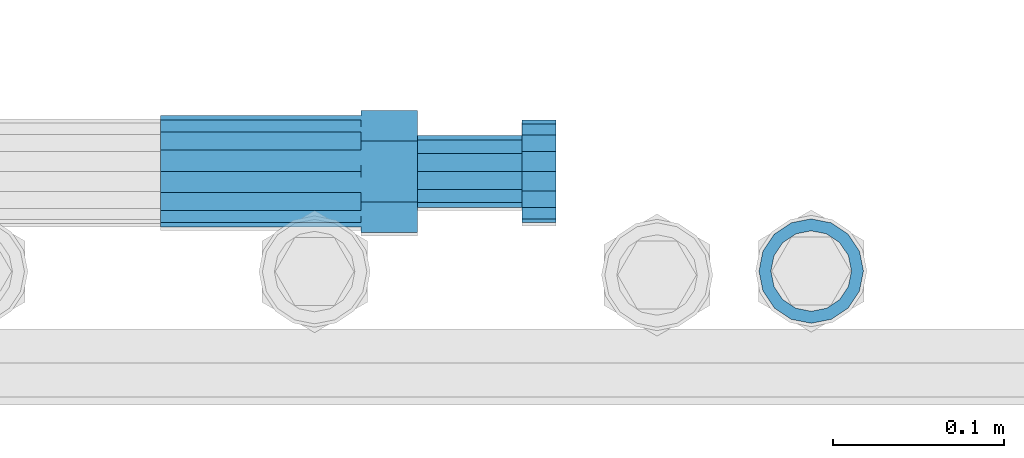
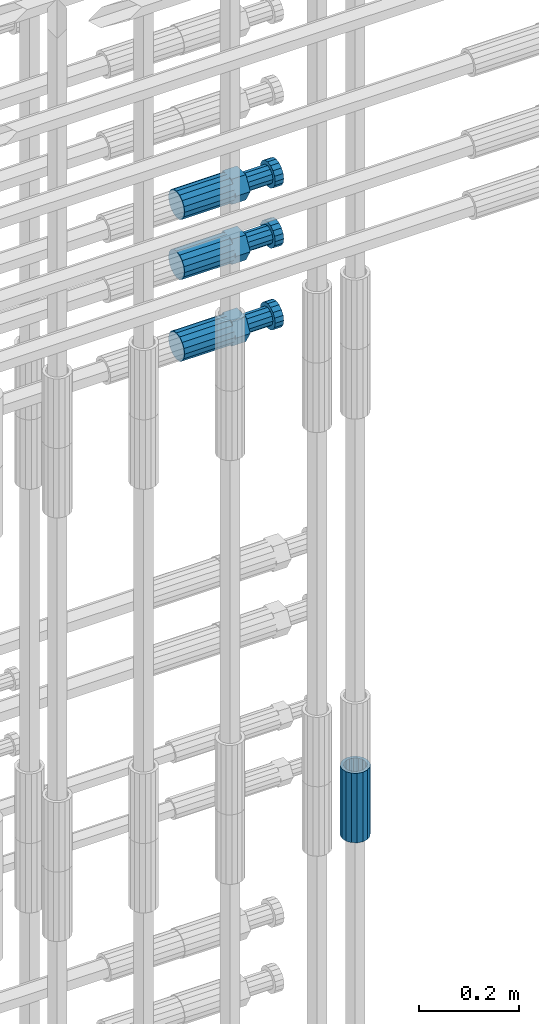
# One storey, part 101 of 119: 4 beams.
"""IFC2X3 building model written with IfcOpenShell, lengths in millimetres."""

from ifc_helpers import new_model, si_unit, frame, origin_with_axes, place, context, subcontext, project, spatial, faceted_brep, material, type_object, element, save


model = new_model("IFC2X3")

# Units and contexts
model_context = context("Model", 3, precision=1e-05, world=origin_with_axes())
body_context = subcontext(model_context, "Body", "Model", "MODEL_VIEW")
ifc_project = project(units=[si_unit("LENGTHUNIT", "METRE", prefix="MILLI"), si_unit("AREAUNIT", "SQUARE_METRE"), si_unit("VOLUMEUNIT", "CUBIC_METRE"), si_unit("MASSUNIT", "GRAM", prefix="KILO"), si_unit("TIMEUNIT", "SECOND"), si_unit("PLANEANGLEUNIT", "RADIAN"), si_unit("SOLIDANGLEUNIT", "STERADIAN"), si_unit("THERMODYNAMICTEMPERATUREUNIT", "DEGREE_CELSIUS"), si_unit("LUMINOUSINTENSITYUNIT", "LUMEN")], contexts=[model_context])

# Site, building, storey
site_placement = place(None, origin_with_axes())
site = spatial("IfcSite", under=ifc_project, at=site_placement, CompositionType="ELEMENT")
building_placement = place(site_placement, origin_with_axes())
building = spatial("IfcBuilding", under=site, at=building_placement, Name="Undefined", CompositionType="ELEMENT")
storey_placement = place(building_placement, origin_with_axes())
storey = spatial("IfcBuildingStorey", under=building, at=storey_placement, Name="Undefined", CompositionType="ELEMENT", Elevation=0.0)

# Beams
ifc_material = material(Name="STEEL/S275")
beam_type_1 = type_object("IfcBeamType", PredefinedType="NOTDEFINED")
beam_1_placement = place(storey_placement, frame((2039119.0136987, 6205156.73095221, 19667.715729163), z_axis=(1.0, 0.0, 0.0), x_axis=(0.0, 0.0, 1.0)))
element("IfcBeam", 1, at=beam_1_placement, inside=storey, type_object=beam_type_1, material=ifc_material, Name="AG40N", context=body_context, shape_type="Brep", body=[
    faceted_brep([(1.62981450557709e-09, -23.4999999990687, 0.0), (7.45058059692383e-09, -21.7111690142192, 8.99306066057534), (170.000002125278, -21.711168999318, 8.99306066022245), (170.000002127141, -23.4999999844003, -3.66071617463604e-10), (4.65661287307739e-09, -16.6170093587134, 16.6170093578889), (170.000002122484, -16.6170093440451, 16.6170093575288), (1.86264514923096e-09, -8.99306066217832, 21.7111690140277), (170.000002118759, -8.99306064750999, 21.7111690136603), (2.3283064365387e-10, 9.31322574615479e-10, 23.5), (170.000002114102, 1.28056854009628e-08, 23.4999999996485), (-6.51925802230835e-09, 8.99306065868586, 21.7111690140241), (170.00000211224, 8.99306067335419, 21.7111690136639), (-7.45058059692383e-09, 16.6170093561523, 16.6170093578853), (170.000002109446, 16.6170093708206, 16.6170093575324), (-9.31322574615479e-09, 21.711169013055, 8.99306066057534), (170.000002108514, 21.7111690277234, 8.99306066022245), (-1.16415321826935e-09, 23.5000000009313, 0.0), (170.000002108514, 23.5000000144355, -3.66071617463604e-10), (-8.38190317153931e-09, 21.7111690151505, -8.99306066059444), (170.000002110377, 21.7111690300517, -8.9930606609546), (-5.58793544769287e-09, 16.6170093598776, -16.6170093579008), (170.000002113171, 16.6170093745459, -16.6170093582609), (-9.31322574615479e-10, 8.99306066334248, -21.7111690140396), (170.000002115965, 8.99306067801081, -21.7111690143961), (2.3283064365387e-10, 9.31322574615479e-10, -23.5), (170.00000211969, 1.7927959561348e-08, -23.5000000003843), (5.58793544769287e-09, -8.99306065752171, -21.7111690140396), (170.000002123415, -8.99306064285338, -21.7111690143961), (8.38190317153931e-09, -16.6170093549881, -16.6170093579008), (170.000002125278, -16.6170093403198, -16.6170093582646), (9.31322574615479e-09, -21.7111690121237, -8.99306066059444), (170.000002127141, -21.7111689972226, -8.9930606609546), (1.11758708953857e-08, -30.4999999990687, -9.54969436861575e-12), (1.30385160446167e-08, -28.1783257392235, -11.6718446871514), (170.000002129003, -28.1783257243223, -11.6718446875116), (170.000002129935, -30.4999999841675, -3.66071617463604e-10), (1.02445483207703e-08, -21.5667568228673, -21.5667568262129), (170.000002128072, -21.566756808199, -21.5667568265694), (7.45058059692383e-09, -11.6718446831219, -28.1783257416196), (170.000002125278, -11.6718446684536, -28.1783257419834), (3.72529029846191e-09, 3.95812094211578e-09, -30.5000000000277), (170.00000211969, 1.83936208486557e-08, -30.5000000003879), (-9.31322574615479e-10, 11.6718446905725, -28.1783257416232), (170.000002115965, 11.6718447052408, -28.1783257419797), (-6.51925802230835e-09, 21.5667568286881, -21.5667568262093), (170.000002110377, 21.5667568433564, -21.5667568265694), (-9.31322574615479e-09, 28.178325742716, -11.6718446871478), (170.000002108514, 28.1783257573843, -11.6718446875079), (-1.21071934700012e-08, 30.5, -5.91171556152403e-12), (170.000002106652, 30.5000000144355, -3.62433638656512e-10), (-1.21071934700012e-08, 28.1783257401548, 11.6718446871359), (170.00000210572, 28.1783257548232, 11.6718446867794), (-1.02445483207703e-08, 21.5667568240315, 21.5667568261974), (170.000002107583, 21.566756838467, 21.5667568258409), (-7.45058059692383e-09, 11.671844684286, 28.1783257416041), (170.000002110377, 11.6718446989544, 28.178325741244), (-2.79396772384644e-09, -2.56113708019257e-09, 30.5000000000159), (170.000002114102, 1.18743628263474e-08, 30.4999999996558), (1.86264514923096e-09, -11.6718446896411, 28.1783257416114), (170.000002118759, -11.67184467474, 28.178325741244), (7.45058059692383e-09, -21.5667568275239, 21.5667568261974), (170.000002123415, -21.5667568126228, 21.5667568258373), (1.02445483207703e-08, -28.1783257415518, 11.6718446871359), (170.000002127141, -28.1783257271163, 11.6718446867794)], [[[0, 1, 2, 3]], [[1, 4, 5, 2]], [[4, 6, 7, 5]], [[6, 8, 9, 7]], [[8, 10, 11, 9]], [[10, 12, 13, 11]], [[12, 14, 15, 13]], [[14, 16, 17, 15]], [[16, 18, 19, 17]], [[18, 20, 21, 19]], [[20, 22, 23, 21]], [[22, 24, 25, 23]], [[24, 26, 27, 25]], [[26, 28, 29, 27]], [[28, 30, 31, 29]], [[30, 0, 3, 31]], [[32, 33, 34, 35]], [[33, 36, 37, 34]], [[36, 38, 39, 37]], [[38, 40, 41, 39]], [[40, 42, 43, 41]], [[42, 44, 45, 43]], [[44, 46, 47, 45]], [[46, 48, 49, 47]], [[48, 50, 51, 49]], [[50, 52, 53, 51]], [[52, 54, 55, 53]], [[54, 56, 57, 55]], [[56, 58, 59, 57]], [[58, 60, 61, 59]], [[60, 62, 63, 61]], [[62, 32, 35, 63]], [[37, 39, 41, 43, 45, 47, 49, 51, 53, 55, 57, 59, 61, 63, 35, 34], [5, 7, 9, 11, 13, 15, 17, 19, 21, 23, 25, 27, 29, 31, 3, 2]], [[62, 60, 58, 56, 54, 52, 50, 48, 46, 44, 42, 40, 38, 36, 33, 32], [30, 28, 26, 24, 22, 20, 18, 16, 14, 12, 10, 8, 6, 4, 1, 0]]]),
])
beam_type_2 = type_object("IfcBeamType", Name="ROD65", PredefinedType="NOTDEFINED")
beam_2_placement = place(storey_placement, frame((2038739.00023304, 6205214.98994599, 21306.9894219673), z_axis=(0.0, 0.0, 1.0), x_axis=(1.0, 0.0, 0.0)))
element("IfcBeam", 2, at=beam_2_placement, inside=storey, type_object=beam_type_2, material=ifc_material, Name="AGB40", ObjectType="ROD65", context=body_context, shape_type="Brep", body=[
    faceted_brep([(116.999999999069, 17.8249999252148, 30.8738056446964), (116.999999998137, 22.0056957420893, 23.632628078838), (116.999999999069, 12.4372115600854, 30.0260848066173), (116.999999999069, 8.17543111252598, 30.8738056446964), (117.000000000931, -17.8250000746921, 30.8738056446964), (150.200000001118, -17.8250000723638, 30.8738056446964), (150.199999999255, 17.8249999275431, 30.8738056446964), (117.000000000931, -8.17543109622784, 30.8738056446964), (117.000000001863, -22.0056959956419, 23.6326278985034), (117.000000000931, -12.4372115437873, 30.0260848066173), (117.000000001863, -35.6500000746455, -2.18278728425503e-10), (150.200000002049, -35.6500000723172, -2.18278728425503e-10), (117.000000001863, -30.8443149488885, 8.32369080289209), (117.000000001863, -30.8443149488885, -8.32369080355784), (117.000000002794, -32.4999999918509, 0.0), (117.000000000931, -17.8250000746921, -30.873805645133), (150.200000001118, -17.8250000723638, -30.873805645133), (117.000000001863, -22.0056959961075, -23.6326278982269), (117.000000000931, -8.17543109389953, -30.873805645133), (117.000000000931, -12.4372115437873, -30.0260848066173), (116.999999999069, 17.8249999252148, -30.873805645133), (150.199999999255, 17.8249999275431, -30.873805645133), (116.999999999069, 8.17543111019768, -30.873805645133), (116.999999999069, 12.4372115600854, -30.0260848066173), (116.999999998137, 22.005695742555, -23.6326280785652), (116.999999998137, 35.6499999251682, -2.18278728425503e-10), (150.199999998324, 35.6499999277294, -2.18278728425503e-10), (116.999999998137, 30.8443150522653, -8.32369036550881), (116.999999997206, 32.5000000081491, 0.0), (116.999999998137, 30.8443150522653, 8.32369036483942), (1.86264514923096e-09, -22.9809703885112, 22.9809703885621), (1.86264514923096e-09, -30.0260848065373, 12.4372115518672), (117.000000001863, -30.0260847983882, 12.4372115518672), (117.000000001863, -22.9809703803621, 22.9809703885621), (-1.86264514923096e-09, 22.9809703885112, -22.9809703885621), (-1.86264514923096e-09, 30.0260848065373, -12.4372115518672), (116.999999998137, 30.0260848146863, -12.4372115518672), (116.999999998137, 22.9809703966603, -22.9809703885621), (1.86264514923096e-09, -30.0260848065373, -12.4372115518672), (1.86264514923096e-09, -22.9809703885112, -22.9809703885621), (117.000000001863, -22.9809703803621, -22.9809703885621), (117.000000001863, -30.0260847983882, -12.4372115518672), (9.31322574615479e-10, -12.4372115519363, 30.0260848066173), (0.0, 0.0, 32.5), (-9.31322574615479e-10, 12.4372115519363, 30.0260848066173), (-1.86264514923096e-09, 22.9809703885112, 22.9809703885621), (-1.86264514923096e-09, 30.0260848065373, 12.4372115518672), (-2.79396772384644e-09, 32.5, 0.0), (-9.31322574615479e-10, 12.4372115519363, -30.0260848066173), (0.0, 0.0, -32.5), (9.31322574615479e-10, -12.4372115519363, -30.0260848066173), (2.79396772384644e-09, -32.5, 0.0), (116.999999998137, 22.9809703966603, 22.9809703885621), (116.999999998137, 30.0260848146863, 12.4372115518672), (117.0, 8.14907252788544e-09, -32.5), (117.0, 8.14907252788544e-09, 32.5), (150.200000000186, -10.5000000959262, 18.1865334791873), (150.199999999255, -9.59262251853943e-08, 20.9999999997126), (150.199999998324, 10.4999999040738, 18.1865334791873), (150.199999997392, 18.1865333835594, 10.4999999997126), (150.199999997392, 20.9999999040738, -2.87400325760245e-10), (150.199999997392, 18.1865333835594, -10.5000000002874), (150.199999998324, 10.4999999040738, -18.1865334797621), (150.199999999255, -9.59262251853943e-08, -21.0000000002874), (150.200000000186, -10.5000000959262, -18.1865334797621), (150.200000000186, -18.1865335754119, -10.5000000002874), (150.200000001118, -21.0000000959262, -2.87400325760245e-10), (150.200000000186, -18.1865335754119, 10.4999999997126), (210.979999999516, 10.4999999082647, 18.1865334791873), (210.979999999516, -9.17352735996246e-08, 20.9999999997126), (210.979999997653, 18.1865333877504, 10.4999999997126), (210.979999997653, 20.9999999082647, -2.87400325760245e-10), (210.979999997653, 18.1865333877504, -10.5000000002874), (210.979999999516, 10.4999999082647, -18.1865334797621), (210.979999999516, -9.17352735996246e-08, -21.0000000002874), (210.979999999516, -10.5000000917353, -18.1865334797621), (210.980000000447, -18.1865335712209, -10.5000000002874), (210.980000001378, -21.0000000917353, -2.87400325760245e-10), (210.980000000447, -18.1865335712209, 10.4999999997126), (210.979999999516, -10.5000000917353, 18.1865334791873), (211.001368402503, -27.7269939335529, -11.4911163272045), (211.003082515672, -21.2238095656503, -21.2238154190527), (231.002518340945, -21.2131946226582, -21.2132004554769), (231.000804228708, -27.7163789905608, -11.4805013636287), (211.001368415542, -11.4911086384673, -27.7269970399575), (231.000804241747, -11.4804936954752, -27.7163820763781), (210.996487061493, -0.0106066407170147, -30.0106107396168), (230.995922887698, 8.30227509140968e-06, -29.999995776041), (210.98918159306, 11.4698940692469, -27.7269970332745), (230.988617419265, 11.4805090120062, -27.7163820696951), (210.980564201251, 21.2025913291145, -21.2238154067054), (230.980000027455, 21.2132062721066, -21.2132004431296), (210.971946807578, 27.7057702087332, -11.4911163110701), (230.971382633783, 27.7163851517253, -11.4805013474943), (210.964641331695, 29.9893806746695, -0.0106149565435771), (230.9640771579, 29.9999956176616, 7.03221303410828e-09), (210.959759964608, 27.7057637346443, 11.4698863966551), (230.959195790812, 27.7163786776364, 11.4805013602345), (210.958045851439, 21.2025793667417, 21.2025854885032), (230.957481677644, 21.2131943097338, 21.2132004520827), (210.959759951569, 11.4698784395587, 27.705767109408), (230.959195776843, 11.4804933823179, 27.7163820729838), (210.964641305618, -0.0106235581915826, 29.9893808090674), (230.964077131823, -8.61519947648048e-06, 29.9999957726432), (210.971946774051, -11.4911242681555, 27.7057671027251), (230.971382599324, -11.4805093251634, 27.7163820663009), (210.98056416586, -21.2238215280231, 21.2025854761559), (230.979999991134, -21.2132065852638, 21.2132004397354), (210.989181559533, -27.7270004076418, 11.4698863805206), (230.988617384806, -27.7163854646496, 11.4805013441), (210.996487035416, -30.0106108735781, -0.0106149740058754), (230.995922861621, -29.999995930586, -1.04300852399319e-08)], [[[0, 1, 2, 3]], [[4, 5, 6, 0, 3, 7]], [[8, 4, 7, 9]], [[10, 11, 5, 4, 8, 12]], [[13, 10, 12, 14]], [[15, 16, 11, 10, 13, 17]], [[18, 15, 17, 19]], [[20, 21, 16, 15, 18, 22]], [[20, 22, 23, 24]], [[25, 26, 21, 20, 24, 27]], [[25, 27, 28, 29]], [[30, 31, 32, 33]], [[34, 35, 36, 37]], [[38, 39, 40, 41]], [[31, 30, 42, 43, 44, 45, 46, 47, 35, 34, 48, 49, 50, 39, 38, 51]], [[46, 45, 52, 53]], [[28, 47, 46, 53, 29]], [[27, 36, 35, 47, 28]], [[24, 37, 36, 27]], [[23, 48, 34, 37, 24]], [[22, 54, 49, 48, 23]], [[18, 54, 22]], [[19, 50, 49, 54, 18]], [[17, 40, 39, 50, 19]], [[13, 41, 40, 17]], [[14, 51, 38, 41, 13]], [[12, 32, 31, 51, 14]], [[8, 33, 32, 12]], [[9, 42, 30, 33, 8]], [[7, 55, 43, 42, 9]], [[3, 55, 7]], [[2, 44, 43, 55, 3]], [[1, 52, 45, 44, 2]], [[29, 53, 52, 1]], [[0, 6, 26, 25, 29, 1]], [[5, 11, 16, 21, 26, 6], [56, 57, 58, 59, 60, 61, 62, 63, 64, 65, 66, 67]], [[68, 58, 57, 69]], [[70, 59, 58, 68]], [[71, 60, 59, 70]], [[72, 61, 60, 71]], [[73, 62, 61, 72]], [[74, 63, 62, 73]], [[75, 64, 63, 74]], [[76, 65, 64, 75]], [[77, 66, 65, 76]], [[78, 67, 66, 77]], [[79, 56, 67, 78]], [[69, 57, 56, 79]], [[80, 81, 82, 83]], [[81, 84, 85, 82]], [[84, 86, 87, 85]], [[86, 88, 89, 87]], [[88, 90, 91, 89]], [[90, 92, 93, 91]], [[92, 94, 95, 93]], [[94, 96, 97, 95]], [[96, 98, 99, 97]], [[98, 100, 101, 99]], [[100, 102, 103, 101]], [[102, 104, 105, 103]], [[104, 106, 107, 105]], [[106, 108, 109, 107]], [[108, 110, 111, 109]], [[82, 85, 87, 89, 91, 93, 95, 97, 99, 101, 103, 105, 107, 109, 111, 83]], [[110, 80, 83, 111]], [[108, 106, 104, 102, 100, 98, 96, 94, 92, 90, 88, 86, 84, 81, 80, 110], [78, 77, 76, 75, 74, 73, 72, 71, 70, 68, 69, 79]]]),
])
beam_3_placement = place(storey_placement, frame((2038739.00023304, 6205214.98994599, 21159.9894219673), z_axis=(0.0, 0.0, 1.0), x_axis=(1.0, 0.0, 0.0)))
element("IfcBeam", 3, at=beam_3_placement, inside=storey, type_object=beam_type_2, material=ifc_material, Name="AGB40", ObjectType="ROD65", context=body_context, shape_type="Brep", body=[
    faceted_brep([(116.999999999069, 17.8249999252148, 30.8738056446964), (116.999999998137, 22.0056957420893, 23.632628078838), (116.999999999069, 12.4372115600854, 30.0260848066173), (116.999999999069, 8.17543111252598, 30.8738056446964), (117.000000000931, -17.8250000746921, 30.8738056446964), (150.200000001118, -17.8250000723638, 30.8738056446964), (150.199999999255, 17.8249999275431, 30.8738056446964), (117.000000000931, -8.17543109622784, 30.8738056446964), (117.000000001863, -22.0056959956419, 23.6326278985034), (117.000000000931, -12.4372115437873, 30.0260848066173), (117.000000001863, -35.6500000746455, -2.18278728425503e-10), (150.200000002049, -35.6500000723172, -2.18278728425503e-10), (117.000000001863, -30.8443149488885, 8.32369080289209), (117.000000001863, -30.8443149488885, -8.32369080355784), (117.000000002794, -32.4999999918509, 0.0), (117.000000000931, -17.8250000746921, -30.873805645133), (150.200000001118, -17.8250000723638, -30.873805645133), (117.000000001863, -22.0056959961075, -23.6326278982269), (117.000000000931, -8.17543109389953, -30.873805645133), (117.000000000931, -12.4372115437873, -30.0260848066173), (116.999999999069, 17.8249999252148, -30.873805645133), (150.199999999255, 17.8249999275431, -30.873805645133), (116.999999999069, 8.17543111019768, -30.873805645133), (116.999999999069, 12.4372115600854, -30.0260848066173), (116.999999998137, 22.005695742555, -23.6326280785652), (116.999999998137, 35.6499999251682, -2.18278728425503e-10), (150.199999998324, 35.6499999277294, -2.18278728425503e-10), (116.999999998137, 30.8443150522653, -8.32369036550881), (116.999999997206, 32.5000000081491, 0.0), (116.999999998137, 30.8443150522653, 8.32369036483942), (1.86264514923096e-09, -22.9809703885112, 22.9809703885621), (1.86264514923096e-09, -30.0260848065373, 12.4372115518672), (117.000000001863, -30.0260847983882, 12.4372115518672), (117.000000001863, -22.9809703803621, 22.9809703885621), (-1.86264514923096e-09, 22.9809703885112, -22.9809703885621), (-1.86264514923096e-09, 30.0260848065373, -12.4372115518672), (116.999999998137, 30.0260848146863, -12.4372115518672), (116.999999998137, 22.9809703966603, -22.9809703885621), (1.86264514923096e-09, -30.0260848065373, -12.4372115518672), (1.86264514923096e-09, -22.9809703885112, -22.9809703885621), (117.000000001863, -22.9809703803621, -22.9809703885621), (117.000000001863, -30.0260847983882, -12.4372115518672), (9.31322574615479e-10, -12.4372115519363, 30.0260848066173), (0.0, 0.0, 32.5), (-9.31322574615479e-10, 12.4372115519363, 30.0260848066173), (-1.86264514923096e-09, 22.9809703885112, 22.9809703885621), (-1.86264514923096e-09, 30.0260848065373, 12.4372115518672), (-2.79396772384644e-09, 32.5, 0.0), (-9.31322574615479e-10, 12.4372115519363, -30.0260848066173), (0.0, 0.0, -32.5), (9.31322574615479e-10, -12.4372115519363, -30.0260848066173), (2.79396772384644e-09, -32.5, 0.0), (116.999999998137, 22.9809703966603, 22.9809703885621), (116.999999998137, 30.0260848146863, 12.4372115518672), (117.0, 8.14907252788544e-09, -32.5), (117.0, 8.14907252788544e-09, 32.5), (150.200000000186, -10.5000000959262, 18.1865334791873), (150.199999999255, -9.59262251853943e-08, 20.9999999997126), (150.199999998324, 10.4999999040738, 18.1865334791873), (150.199999997392, 18.1865333835594, 10.4999999997126), (150.199999997392, 20.9999999040738, -2.87400325760245e-10), (150.199999997392, 18.1865333835594, -10.5000000002874), (150.199999998324, 10.4999999040738, -18.1865334797621), (150.199999999255, -9.59262251853943e-08, -21.0000000002874), (150.200000000186, -10.5000000959262, -18.1865334797621), (150.200000000186, -18.1865335754119, -10.5000000002874), (150.200000001118, -21.0000000959262, -2.87400325760245e-10), (150.200000000186, -18.1865335754119, 10.4999999997126), (210.979999999516, 10.4999999082647, 18.1865334791873), (210.979999999516, -9.17352735996246e-08, 20.9999999997126), (210.979999997653, 18.1865333877504, 10.4999999997126), (210.979999997653, 20.9999999082647, -2.87400325760245e-10), (210.979999997653, 18.1865333877504, -10.5000000002874), (210.979999999516, 10.4999999082647, -18.1865334797621), (210.979999999516, -9.17352735996246e-08, -21.0000000002874), (210.979999999516, -10.5000000917353, -18.1865334797621), (210.980000000447, -18.1865335712209, -10.5000000002874), (210.980000001378, -21.0000000917353, -2.87400325760245e-10), (210.980000000447, -18.1865335712209, 10.4999999997126), (210.979999999516, -10.5000000917353, 18.1865334791873), (211.001368402503, -27.7269939335529, -11.4911163272045), (211.003082515672, -21.2238095656503, -21.2238154190527), (231.002518340945, -21.2131946226582, -21.2132004554769), (231.000804228708, -27.7163789905608, -11.4805013636287), (211.001368415542, -11.4911086384673, -27.7269970399575), (231.000804241747, -11.4804936954752, -27.7163820763781), (210.996487061493, -0.0106066407170147, -30.0106107396168), (230.995922887698, 8.30227509140968e-06, -29.999995776041), (210.98918159306, 11.4698940692469, -27.7269970332745), (230.988617419265, 11.4805090120062, -27.7163820696951), (210.980564201251, 21.2025913291145, -21.2238154067054), (230.980000027455, 21.2132062721066, -21.2132004431296), (210.971946807578, 27.7057702087332, -11.4911163110701), (230.971382633783, 27.7163851517253, -11.4805013474943), (210.964641331695, 29.9893806746695, -0.0106149565435771), (230.9640771579, 29.9999956176616, 7.03221303410828e-09), (210.959759964608, 27.7057637346443, 11.4698863966551), (230.959195790812, 27.7163786776364, 11.4805013602345), (210.958045851439, 21.2025793667417, 21.2025854885032), (230.957481677644, 21.2131943097338, 21.2132004520827), (210.959759951569, 11.4698784395587, 27.705767109408), (230.959195776843, 11.4804933823179, 27.7163820729838), (210.964641305618, -0.0106235581915826, 29.9893808090674), (230.964077131823, -8.61519947648048e-06, 29.9999957726432), (210.971946774051, -11.4911242681555, 27.7057671027251), (230.971382599324, -11.4805093251634, 27.7163820663009), (210.98056416586, -21.2238215280231, 21.2025854761559), (230.979999991134, -21.2132065852638, 21.2132004397354), (210.989181559533, -27.7270004076418, 11.4698863805206), (230.988617384806, -27.7163854646496, 11.4805013441), (210.996487035416, -30.0106108735781, -0.0106149740058754), (230.995922861621, -29.999995930586, -1.04300852399319e-08)], [[[0, 1, 2, 3]], [[4, 5, 6, 0, 3, 7]], [[8, 4, 7, 9]], [[10, 11, 5, 4, 8, 12]], [[13, 10, 12, 14]], [[15, 16, 11, 10, 13, 17]], [[18, 15, 17, 19]], [[20, 21, 16, 15, 18, 22]], [[20, 22, 23, 24]], [[25, 26, 21, 20, 24, 27]], [[25, 27, 28, 29]], [[30, 31, 32, 33]], [[34, 35, 36, 37]], [[38, 39, 40, 41]], [[31, 30, 42, 43, 44, 45, 46, 47, 35, 34, 48, 49, 50, 39, 38, 51]], [[46, 45, 52, 53]], [[28, 47, 46, 53, 29]], [[27, 36, 35, 47, 28]], [[24, 37, 36, 27]], [[23, 48, 34, 37, 24]], [[22, 54, 49, 48, 23]], [[18, 54, 22]], [[19, 50, 49, 54, 18]], [[17, 40, 39, 50, 19]], [[13, 41, 40, 17]], [[14, 51, 38, 41, 13]], [[12, 32, 31, 51, 14]], [[8, 33, 32, 12]], [[9, 42, 30, 33, 8]], [[7, 55, 43, 42, 9]], [[3, 55, 7]], [[2, 44, 43, 55, 3]], [[1, 52, 45, 44, 2]], [[29, 53, 52, 1]], [[0, 6, 26, 25, 29, 1]], [[5, 11, 16, 21, 26, 6], [56, 57, 58, 59, 60, 61, 62, 63, 64, 65, 66, 67]], [[68, 58, 57, 69]], [[70, 59, 58, 68]], [[71, 60, 59, 70]], [[72, 61, 60, 71]], [[73, 62, 61, 72]], [[74, 63, 62, 73]], [[75, 64, 63, 74]], [[76, 65, 64, 75]], [[77, 66, 65, 76]], [[78, 67, 66, 77]], [[79, 56, 67, 78]], [[69, 57, 56, 79]], [[80, 81, 82, 83]], [[81, 84, 85, 82]], [[84, 86, 87, 85]], [[86, 88, 89, 87]], [[88, 90, 91, 89]], [[90, 92, 93, 91]], [[92, 94, 95, 93]], [[94, 96, 97, 95]], [[96, 98, 99, 97]], [[98, 100, 101, 99]], [[100, 102, 103, 101]], [[102, 104, 105, 103]], [[104, 106, 107, 105]], [[106, 108, 109, 107]], [[108, 110, 111, 109]], [[82, 85, 87, 89, 91, 93, 95, 97, 99, 101, 103, 105, 107, 109, 111, 83]], [[110, 80, 83, 111]], [[108, 106, 104, 102, 100, 98, 96, 94, 92, 90, 88, 86, 84, 81, 80, 110], [78, 77, 76, 75, 74, 73, 72, 71, 70, 68, 69, 79]]]),
])
beam_4_placement = place(storey_placement, frame((2038739.00023304, 6205214.98994599, 20959.9894220935), z_axis=(0.0, 0.0, 1.0), x_axis=(1.0, 0.0, 0.0)))
element("IfcBeam", 4, at=beam_4_placement, inside=storey, type_object=beam_type_2, material=ifc_material, Name="AGB40", ObjectType="ROD65", context=body_context, shape_type="Brep", body=[
    faceted_brep([(116.999999999069, 17.8249999252148, 30.8738056446964), (116.999999998137, 22.0056957420893, 23.632628078838), (116.999999999069, 12.4372115600854, 30.0260848066173), (116.999999999069, 8.17543111252598, 30.8738056446964), (117.000000000931, -17.8250000746921, 30.8738056446964), (150.200000001118, -17.8250000723638, 30.8738056446964), (150.199999999255, 17.8249999275431, 30.8738056446964), (117.000000000931, -8.17543109622784, 30.8738056446964), (117.000000001863, -22.0056959956419, 23.6326278985034), (117.000000000931, -12.4372115437873, 30.0260848066173), (117.000000001863, -35.6500000746455, -2.18278728425503e-10), (150.200000002049, -35.6500000723172, -2.18278728425503e-10), (117.000000001863, -30.8443149488885, 8.32369080289209), (117.000000001863, -30.8443149488885, -8.32369080355784), (117.000000002794, -32.4999999918509, 0.0), (117.000000000931, -17.8250000746921, -30.873805645133), (150.200000001118, -17.8250000723638, -30.873805645133), (117.000000001863, -22.0056959961075, -23.6326278982269), (117.000000000931, -8.17543109389953, -30.873805645133), (117.000000000931, -12.4372115437873, -30.0260848066173), (116.999999999069, 17.8249999252148, -30.873805645133), (150.199999999255, 17.8249999275431, -30.873805645133), (116.999999999069, 8.17543111019768, -30.873805645133), (116.999999999069, 12.4372115600854, -30.0260848066173), (116.999999998137, 22.005695742555, -23.6326280785652), (116.999999998137, 35.6499999251682, -2.18278728425503e-10), (150.199999998324, 35.6499999277294, -2.18278728425503e-10), (116.999999998137, 30.8443150522653, -8.32369036550881), (116.999999997206, 32.5000000081491, 0.0), (116.999999998137, 30.8443150522653, 8.32369036483942), (1.86264514923096e-09, -22.9809703885112, 22.9809703885621), (1.86264514923096e-09, -30.0260848065373, 12.4372115518672), (117.000000001863, -30.0260847983882, 12.4372115518672), (117.000000001863, -22.9809703803621, 22.9809703885621), (-1.86264514923096e-09, 22.9809703885112, -22.9809703885621), (-1.86264514923096e-09, 30.0260848065373, -12.4372115518672), (116.999999998137, 30.0260848146863, -12.4372115518672), (116.999999998137, 22.9809703966603, -22.9809703885621), (1.86264514923096e-09, -30.0260848065373, -12.4372115518672), (1.86264514923096e-09, -22.9809703885112, -22.9809703885621), (117.000000001863, -22.9809703803621, -22.9809703885621), (117.000000001863, -30.0260847983882, -12.4372115518672), (9.31322574615479e-10, -12.4372115519363, 30.0260848066173), (0.0, 0.0, 32.5), (-9.31322574615479e-10, 12.4372115519363, 30.0260848066173), (-1.86264514923096e-09, 22.9809703885112, 22.9809703885621), (-1.86264514923096e-09, 30.0260848065373, 12.4372115518672), (-2.79396772384644e-09, 32.5, 0.0), (-9.31322574615479e-10, 12.4372115519363, -30.0260848066173), (0.0, 0.0, -32.5), (9.31322574615479e-10, -12.4372115519363, -30.0260848066173), (2.79396772384644e-09, -32.5, 0.0), (116.999999998137, 22.9809703966603, 22.9809703885621), (116.999999998137, 30.0260848146863, 12.4372115518672), (117.0, 8.14907252788544e-09, -32.5), (117.0, 8.14907252788544e-09, 32.5), (150.200000000186, -10.5000000959262, 18.1865334791873), (150.199999999255, -9.59262251853943e-08, 20.9999999997126), (150.199999998324, 10.4999999040738, 18.1865334791873), (150.199999997392, 18.1865333835594, 10.4999999997126), (150.199999997392, 20.9999999040738, -2.87400325760245e-10), (150.199999997392, 18.1865333835594, -10.5000000002874), (150.199999998324, 10.4999999040738, -18.1865334797621), (150.199999999255, -9.59262251853943e-08, -21.0000000002874), (150.200000000186, -10.5000000959262, -18.1865334797621), (150.200000000186, -18.1865335754119, -10.5000000002874), (150.200000001118, -21.0000000959262, -2.87400325760245e-10), (150.200000000186, -18.1865335754119, 10.4999999997126), (210.979999999516, 10.4999999082647, 18.1865334791873), (210.979999999516, -9.17352735996246e-08, 20.9999999997126), (210.979999997653, 18.1865333877504, 10.4999999997126), (210.979999997653, 20.9999999082647, -2.87400325760245e-10), (210.979999997653, 18.1865333877504, -10.5000000002874), (210.979999999516, 10.4999999082647, -18.1865334797621), (210.979999999516, -9.17352735996246e-08, -21.0000000002874), (210.979999999516, -10.5000000917353, -18.1865334797621), (210.980000000447, -18.1865335712209, -10.5000000002874), (210.980000001378, -21.0000000917353, -2.87400325760245e-10), (210.980000000447, -18.1865335712209, 10.4999999997126), (210.979999999516, -10.5000000917353, 18.1865334791873), (211.001368402503, -27.7269939335529, -11.4911163272045), (211.003082515672, -21.2238095656503, -21.2238154190527), (231.002518340945, -21.2131946226582, -21.2132004554769), (231.000804228708, -27.7163789905608, -11.4805013636287), (211.001368415542, -11.4911086384673, -27.7269970399575), (231.000804241747, -11.4804936954752, -27.7163820763781), (210.996487061493, -0.0106066407170147, -30.0106107396168), (230.995922887698, 8.30227509140968e-06, -29.999995776041), (210.98918159306, 11.4698940692469, -27.7269970332745), (230.988617419265, 11.4805090120062, -27.7163820696951), (210.980564201251, 21.2025913291145, -21.2238154067054), (230.980000027455, 21.2132062721066, -21.2132004431296), (210.971946807578, 27.7057702087332, -11.4911163110701), (230.971382633783, 27.7163851517253, -11.4805013474943), (210.964641331695, 29.9893806746695, -0.0106149565435771), (230.9640771579, 29.9999956176616, 7.03221303410828e-09), (210.959759964608, 27.7057637346443, 11.4698863966551), (230.959195790812, 27.7163786776364, 11.4805013602345), (210.958045851439, 21.2025793667417, 21.2025854885032), (230.957481677644, 21.2131943097338, 21.2132004520827), (210.959759951569, 11.4698784395587, 27.705767109408), (230.959195776843, 11.4804933823179, 27.7163820729838), (210.964641305618, -0.0106235581915826, 29.9893808090674), (230.964077131823, -8.61519947648048e-06, 29.9999957726432), (210.971946774051, -11.4911242681555, 27.7057671027251), (230.971382599324, -11.4805093251634, 27.7163820663009), (210.98056416586, -21.2238215280231, 21.2025854761559), (230.979999991134, -21.2132065852638, 21.2132004397354), (210.989181559533, -27.7270004076418, 11.4698863805206), (230.988617384806, -27.7163854646496, 11.4805013441), (210.996487035416, -30.0106108735781, -0.0106149740058754), (230.995922861621, -29.999995930586, -1.04300852399319e-08)], [[[0, 1, 2, 3]], [[4, 5, 6, 0, 3, 7]], [[8, 4, 7, 9]], [[10, 11, 5, 4, 8, 12]], [[13, 10, 12, 14]], [[15, 16, 11, 10, 13, 17]], [[18, 15, 17, 19]], [[20, 21, 16, 15, 18, 22]], [[20, 22, 23, 24]], [[25, 26, 21, 20, 24, 27]], [[25, 27, 28, 29]], [[30, 31, 32, 33]], [[34, 35, 36, 37]], [[38, 39, 40, 41]], [[31, 30, 42, 43, 44, 45, 46, 47, 35, 34, 48, 49, 50, 39, 38, 51]], [[46, 45, 52, 53]], [[28, 47, 46, 53, 29]], [[27, 36, 35, 47, 28]], [[24, 37, 36, 27]], [[23, 48, 34, 37, 24]], [[22, 54, 49, 48, 23]], [[18, 54, 22]], [[19, 50, 49, 54, 18]], [[17, 40, 39, 50, 19]], [[13, 41, 40, 17]], [[14, 51, 38, 41, 13]], [[12, 32, 31, 51, 14]], [[8, 33, 32, 12]], [[9, 42, 30, 33, 8]], [[7, 55, 43, 42, 9]], [[3, 55, 7]], [[2, 44, 43, 55, 3]], [[1, 52, 45, 44, 2]], [[29, 53, 52, 1]], [[0, 6, 26, 25, 29, 1]], [[5, 11, 16, 21, 26, 6], [56, 57, 58, 59, 60, 61, 62, 63, 64, 65, 66, 67]], [[68, 58, 57, 69]], [[70, 59, 58, 68]], [[71, 60, 59, 70]], [[72, 61, 60, 71]], [[73, 62, 61, 72]], [[74, 63, 62, 73]], [[75, 64, 63, 74]], [[76, 65, 64, 75]], [[77, 66, 65, 76]], [[78, 67, 66, 77]], [[79, 56, 67, 78]], [[69, 57, 56, 79]], [[80, 81, 82, 83]], [[81, 84, 85, 82]], [[84, 86, 87, 85]], [[86, 88, 89, 87]], [[88, 90, 91, 89]], [[90, 92, 93, 91]], [[92, 94, 95, 93]], [[94, 96, 97, 95]], [[96, 98, 99, 97]], [[98, 100, 101, 99]], [[100, 102, 103, 101]], [[102, 104, 105, 103]], [[104, 106, 107, 105]], [[106, 108, 109, 107]], [[108, 110, 111, 109]], [[82, 85, 87, 89, 91, 93, 95, 97, 99, 101, 103, 105, 107, 109, 111, 83]], [[110, 80, 83, 111]], [[108, 106, 104, 102, 100, 98, 96, 94, 92, 90, 88, 86, 84, 81, 80, 110], [78, 77, 76, 75, 74, 73, 72, 71, 70, 68, 69, 79]]]),
])

save(model, "model.ifc")
